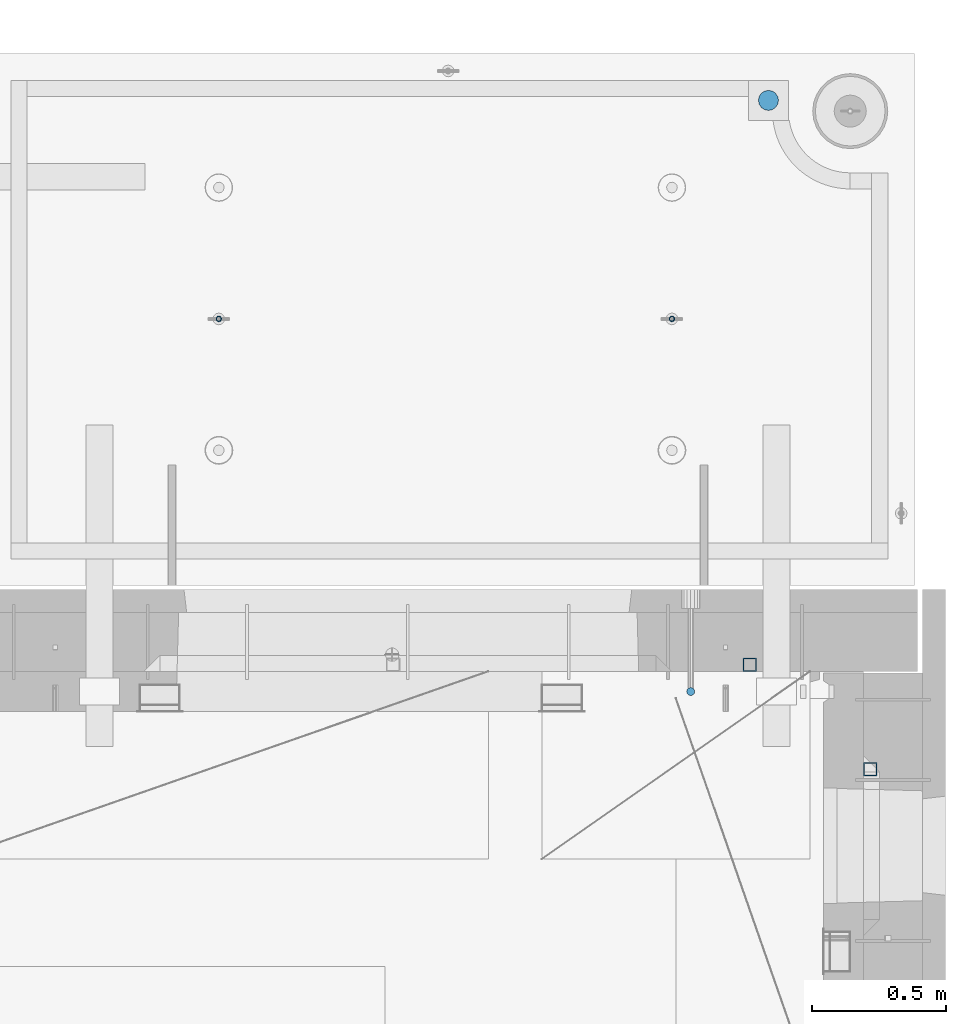
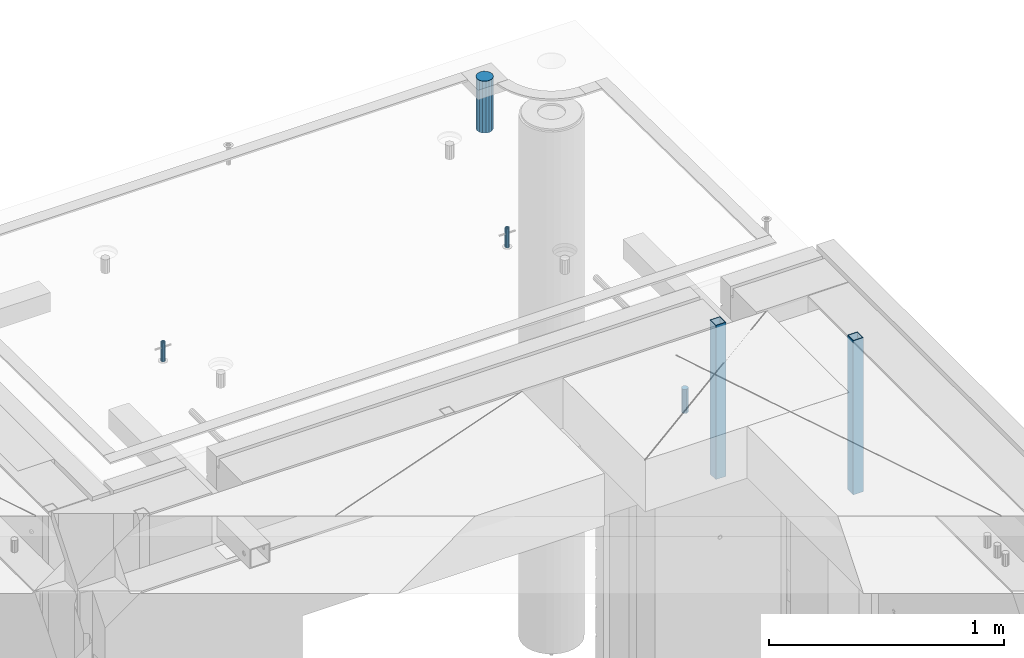
# One storey, part 37 of 350: 6 columns, 7 elements without a shape of their own.
"""IFC2X3 building model written with IfcOpenShell, lengths in millimetres."""

from ifc_helpers import new_model, si_unit, frame, origin_with_axes, place, context, subcontext, project, spatial, faceted_brep, material, type_object, element, aggregate, save


model = new_model("IFC2X3")

# Units and contexts
model_context = context("Model", 3, precision=1e-05, world=origin_with_axes())
body_context = subcontext(model_context, "Body", "Model", "MODEL_VIEW")
ifc_project = project(units=[si_unit("LENGTHUNIT", "METRE", prefix="MILLI"), si_unit("AREAUNIT", "SQUARE_METRE"), si_unit("VOLUMEUNIT", "CUBIC_METRE"), si_unit("MASSUNIT", "GRAM", prefix="KILO"), si_unit("TIMEUNIT", "SECOND"), si_unit("PLANEANGLEUNIT", "RADIAN"), si_unit("SOLIDANGLEUNIT", "STERADIAN"), si_unit("THERMODYNAMICTEMPERATUREUNIT", "DEGREE_CELSIUS"), si_unit("LUMINOUSINTENSITYUNIT", "LUMEN")], contexts=[model_context])

# Site, building, storey
site_placement = place(None, origin_with_axes())
site = spatial("IfcSite", under=ifc_project, at=site_placement, CompositionType="ELEMENT")
building_placement = place(site_placement, origin_with_axes())
building = spatial("IfcBuilding", under=site, at=building_placement, CompositionType="ELEMENT")
storey_placement = place(building_placement, origin_with_axes())
storey = spatial("IfcBuildingStorey", under=building, at=storey_placement, Name="2", CompositionType="ELEMENT", Elevation=0.0)

# Assembly, column
assembly_1_placement = place(storey_placement, origin_with_axes())
assembly_1 = element("IfcElementAssembly", 1, at=assembly_1_placement, inside=storey, AssemblyPlace="NOTDEFINED", PredefinedType="REINFORCEMENT_UNIT")
ifc_material_1 = material()
column_type_1 = type_object("IfcColumnType", Name="D30", PredefinedType="NOTDEFINED")
column_1_placement = place(assembly_1_placement, frame((34415.0073334623, 20504.9951872205, 87407.5), z_axis=(0.0, -1.0, 0.0), x_axis=(0.0, 0.0, 1.0)))
column_1 = element("IfcColumn", 2, at=column_1_placement, type_object=column_type_1, material=ifc_material_1, ObjectType="D30", context=body_context, shape_type="Brep", body=[
    faceted_brep([(0.0, -15.0, 0.0), (0.0, -12.9903810567666, -7.5), (125.0, -12.9903810567666, -7.5), (125.0, -15.0, 0.0), (0.0, -7.5, -12.9903810567666), (125.0, -7.5, -12.9903810567666), (0.0, 0.0, -15.0), (125.0, 0.0, -15.0), (0.0, 7.5, -12.9903810567666), (125.0, 7.5, -12.9903810567666), (0.0, 12.9903810567666, -7.5), (125.0, 12.9903810567666, -7.5), (0.0, 15.0, 0.0), (125.0, 15.0, 0.0), (0.0, 12.9903810567666, 7.5), (125.0, 12.9903810567666, 7.5), (0.0, 7.5, 12.9903810567666), (125.0, 7.5, 12.9903810567666), (0.0, 0.0, 15.0), (125.0, 0.0, 15.0), (0.0, -7.5, 12.9903810567666), (125.0, -7.5, 12.9903810567666), (0.0, -12.9903810567666, 7.5), (125.0, -12.9903810567666, 7.5)], [[[0, 1, 2, 3]], [[1, 4, 5, 2]], [[4, 6, 7, 5]], [[6, 8, 9, 7]], [[8, 10, 11, 9]], [[10, 12, 13, 11]], [[12, 14, 15, 13]], [[14, 16, 17, 15]], [[16, 18, 19, 17]], [[18, 20, 21, 19]], [[20, 22, 23, 21]], [[22, 0, 3, 23]], [[5, 7, 9, 11, 13, 15, 17, 19, 21, 23, 3, 2]], [[22, 20, 18, 16, 14, 12, 10, 8, 6, 4, 1, 0]]]),
])

# Assemblies, column
assembly_2_placement = place(storey_placement, origin_with_axes())
assembly_2 = element("IfcElementAssembly", 3, at=assembly_2_placement, inside=storey, AssemblyPlace="NOTDEFINED", PredefinedType="REINFORCEMENT_UNIT")
assembly_3_placement = place(assembly_2_placement, origin_with_axes())
assembly_3 = element("IfcElementAssembly", 4, at=assembly_3_placement, Name="Steel Assembly", AssemblyPlace="NOTDEFINED", PredefinedType="RIGID_FRAME")
aggregate(assembly_2, [assembly_3])
ifc_material_2 = material(Name="STEEL/S355J2")
column_type_2 = type_object("IfcColumnType", Name="50X50X3", PredefinedType="NOTDEFINED")
column_2_placement = place(assembly_3_placement, frame((35085.0, 20215.0002861023, 86940.0), z_axis=(0.0, -1.0, 0.0), x_axis=(0.0, 0.0, 1.0)))
column_2 = element("IfcColumn", 5, at=column_2_placement, type_object=column_type_2, material=ifc_material_2, ObjectType="50X50X3", context=body_context, shape_type="Brep", body=[
    faceted_brep([(0.0, 22.0, -22.0), (0.0, -22.0, -22.0), (800.0, -22.0, -22.0), (800.0, 22.0, -22.0), (0.0, -22.0, 22.0), (800.0, -22.0, 22.0), (0.0, 22.0, 22.0), (800.0, 22.0, 22.0), (0.0, 25.0, -25.0), (0.0, 25.0, 25.0), (800.0, 25.0, 25.0), (800.0, 25.0, -25.0), (0.0, -25.0, 25.0), (800.0, -25.0, 25.0), (0.0, -25.0, -25.0), (800.0, -25.0, -25.0)], [[[0, 1, 2, 3]], [[1, 4, 5, 2]], [[4, 6, 7, 5]], [[6, 0, 3, 7]], [[8, 9, 10, 11]], [[9, 12, 13, 10]], [[12, 14, 15, 13]], [[14, 8, 11, 15]], [[13, 15, 11, 10], [5, 7, 3, 2]], [[14, 12, 9, 8], [6, 4, 1, 0]]]),
])
aggregate(assembly_3, [column_2])

# Assembly
assembly_4_placement = place(assembly_1_placement, origin_with_axes())
assembly_4 = element("IfcElementAssembly", 6, at=assembly_4_placement, Name="Steel Assembly", AssemblyPlace="NOTDEFINED", PredefinedType="RIGID_FRAME")

aggregate(assembly_1, [column_1, assembly_4])

# Column
column_3_placement = place(assembly_4_placement, frame((34635.0, 20605.0, 86940.0), z_axis=(1.0, 0.0, 0.0), x_axis=(0.0, 0.0, 1.0)))
column_3 = element("IfcColumn", 7, at=column_3_placement, type_object=column_type_2, material=ifc_material_2, ObjectType="50X50X3", context=body_context, shape_type="Brep", body=[
    faceted_brep([(0.0, 22.0, -22.0), (0.0, -22.0, -22.0), (800.0, -22.0, -22.0), (800.0, 22.0, -22.0), (0.0, -22.0, 22.0), (800.0, -22.0, 22.0), (0.0, 22.0, 22.0), (800.0, 22.0, 22.0), (0.0, 25.0, -25.0), (0.0, 25.0, 25.0), (800.0, 25.0, 25.0), (800.0, 25.0, -25.0), (0.0, -25.0, 25.0), (800.0, -25.0, 25.0), (0.0, -25.0, -25.0), (800.0, -25.0, -25.0)], [[[0, 1, 2, 3]], [[1, 4, 5, 2]], [[4, 6, 7, 5]], [[6, 0, 3, 7]], [[8, 9, 10, 11]], [[9, 12, 13, 10]], [[12, 14, 15, 13]], [[14, 8, 11, 15]], [[13, 15, 11, 10], [5, 7, 3, 2]], [[14, 12, 9, 8], [6, 4, 1, 0]]]),
])

aggregate(assembly_4, [column_3])

# Assemblies, columns
assembly_5_placement = place(storey_placement, origin_with_axes())
assembly_5 = element("IfcElementAssembly", 8, at=assembly_5_placement, inside=storey, AssemblyPlace="NOTDEFINED", PredefinedType="REINFORCEMENT_UNIT")
assembly_6_placement = place(assembly_5_placement, origin_with_axes())
assembly_6 = element("IfcElementAssembly", 9, at=assembly_6_placement, Name="Steel Assembly", AssemblyPlace="NOTDEFINED", PredefinedType="RIGID_FRAME")
ifc_material_3 = material(Name="STEEL/1.4301")
column_type_3 = type_object("IfcColumnType", PredefinedType="NOTDEFINED")
column_4_placement = place(assembly_6_placement, frame((32654.9901431868, 21895.0034426477, 87445.0), z_axis=(0.000321686000089053, -0.999999948259057, 0.0), x_axis=(0.0, 0.0, 1.0)))
column_4 = element("IfcColumn", 10, at=column_4_placement, type_object=column_type_3, material=ifc_material_3, context=body_context, shape_type="Brep", body=[
    faceted_brep([(0.0, -8.0, 0.0), (0.0, -6.92820323027263, 4.0), (100.000000000029, -6.92820323027263, 4.0), (100.000000000029, -7.99999999999636, 0.0), (0.0, -4.0, 6.92820323027627), (100.000000000029, -4.0, 6.92820323027536), (0.0, 0.0, 8.0), (100.000000000029, 3.63797880709171e-12, 8.0), (0.0, 4.0, 6.92820323027627), (100.000000000029, 4.0, 6.92820323027536), (0.0, 6.92820323027263, 4.0), (100.000000000029, 6.92820323027627, 3.99999999999909), (0.0, 8.0, 0.0), (100.000000000029, 8.0, 0.0), (0.0, 6.92820323027263, -4.0), (100.000000000029, 6.92820323027627, -4.00000000000091), (0.0, 4.0, -6.92820323027627), (100.000000000029, 4.00000000000364, -6.92820323027536), (0.0, 0.0, -8.0), (100.000000000029, 3.63797880709171e-12, -8.00000000000091), (0.0, -4.0, -6.92820323027627), (100.000000000029, -3.99999999999636, -6.92820323027627), (0.0, -6.92820323027263, -4.0), (100.000000000029, -6.92820323027263, -4.0), (0.0, -10.4999999999927, -1.45519152283669e-11), (0.0, -9.09326673972828, -5.25000000001455), (100.000000000262, -9.09326673972828, -5.25000000001455), (100.000000000262, -10.4999999999927, -1.45519152283669e-11), (0.0, -5.24999999998545, -9.09326673974283), (100.000000000262, -5.24999999998545, -9.09326673974283), (0.0, 7.27595761418343e-12, -10.5), (100.000000000262, 7.27595761418343e-12, -10.5), (0.0, 5.25000000001455, -9.09326673975738), (100.000000000262, 5.25000000001455, -9.09326673975738), (0.0, 9.09326673975011, -5.25000000001455), (100.000000000262, 9.09326673975011, -5.25000000001455), (0.0, 10.5000000000073, -1.45519152283669e-11), (100.000000000262, 10.5000000000073, -1.45519152283669e-11), (0.0, 9.09326673975011, 5.25), (100.000000000262, 9.09326673975011, 5.25), (0.0, 5.25000000000728, 9.09326673972828), (100.000000000262, 5.25000000000728, 9.09326673972828), (0.0, 1.45519152283669e-11, 10.4999999999854), (100.000000000262, 1.45519152283669e-11, 10.4999999999854), (0.0, -5.24999999999272, 9.09326673972828), (100.000000000262, -5.24999999999272, 9.09326673972828), (0.0, -9.09326673972828, 5.24999999998545), (100.000000000262, -9.09326673972828, 5.24999999998545)], [[[0, 1, 2, 3]], [[1, 4, 5, 2]], [[4, 6, 7, 5]], [[6, 8, 9, 7]], [[8, 10, 11, 9]], [[10, 12, 13, 11]], [[12, 14, 15, 13]], [[14, 16, 17, 15]], [[16, 18, 19, 17]], [[18, 20, 21, 19]], [[20, 22, 23, 21]], [[22, 0, 3, 23]], [[24, 25, 26, 27]], [[25, 28, 29, 26]], [[28, 30, 31, 29]], [[30, 32, 33, 31]], [[32, 34, 35, 33]], [[34, 36, 37, 35]], [[36, 38, 39, 37]], [[38, 40, 41, 39]], [[40, 42, 43, 41]], [[42, 44, 45, 43]], [[44, 46, 47, 45]], [[46, 24, 27, 47]], [[29, 31, 33, 35, 37, 39, 41, 43, 45, 47, 27, 26], [5, 7, 9, 11, 13, 15, 17, 19, 21, 23, 3, 2]], [[46, 44, 42, 40, 38, 36, 34, 32, 30, 28, 25, 24], [22, 20, 18, 16, 14, 12, 10, 8, 6, 4, 1, 0]]]),
])
aggregate(assembly_6, [column_4])
assembly_7_placement = place(assembly_5_placement, origin_with_axes())
assembly_7 = element("IfcElementAssembly", 11, at=assembly_7_placement, Name="Steel Assembly", AssemblyPlace="NOTDEFINED", PredefinedType="RIGID_FRAME")
column_5_placement = place(assembly_7_placement, frame((34345.0001431868, 21895.0034426477, 87445.0), z_axis=(0.000321686000089053, -0.999999948259057, 0.0), x_axis=(0.0, 0.0, 1.0)))
column_5 = element("IfcColumn", 12, at=column_5_placement, type_object=column_type_3, material=ifc_material_3, context=body_context, shape_type="Brep", body=[
    faceted_brep([(0.0, -8.0, 0.0), (0.0, -6.92820323027263, 4.0), (100.000000000029, -6.92820323027263, 4.0), (100.000000000029, -7.99999999999636, 0.0), (0.0, -4.0, 6.92820323027627), (100.000000000029, -4.0, 6.92820323027536), (0.0, 0.0, 8.0), (100.000000000029, 3.63797880709171e-12, 8.0), (0.0, 4.0, 6.92820323027627), (100.000000000029, 4.0, 6.92820323027536), (0.0, 6.92820323027263, 4.0), (100.000000000029, 6.92820323027627, 3.99999999999909), (0.0, 8.0, 0.0), (100.000000000029, 8.0, 0.0), (0.0, 6.92820323027263, -4.0), (100.000000000029, 6.92820323027627, -4.00000000000091), (0.0, 4.0, -6.92820323027627), (100.000000000029, 4.00000000000364, -6.92820323027536), (0.0, 0.0, -8.0), (100.000000000029, 3.63797880709171e-12, -8.00000000000091), (0.0, -4.0, -6.92820323027627), (100.000000000029, -3.99999999999636, -6.92820323027627), (0.0, -6.92820323027263, -4.0), (100.000000000029, -6.92820323027263, -4.0), (0.0, -10.4999999999927, -1.45519152283669e-11), (0.0, -9.09326673972828, -5.25000000001455), (100.000000000262, -9.09326673972828, -5.25000000001455), (100.000000000262, -10.4999999999927, -1.45519152283669e-11), (0.0, -5.24999999998545, -9.09326673974283), (100.000000000262, -5.24999999998545, -9.09326673974283), (0.0, 7.27595761418343e-12, -10.5), (100.000000000262, 7.27595761418343e-12, -10.5), (0.0, 5.25000000001455, -9.09326673975738), (100.000000000262, 5.25000000001455, -9.09326673975738), (0.0, 9.09326673975011, -5.25000000001455), (100.000000000262, 9.09326673975011, -5.25000000001455), (0.0, 10.5000000000073, -1.45519152283669e-11), (100.000000000262, 10.5000000000073, -1.45519152283669e-11), (0.0, 9.09326673975011, 5.25), (100.000000000262, 9.09326673975011, 5.25), (0.0, 5.25000000000728, 9.09326673972828), (100.000000000262, 5.25000000000728, 9.09326673972828), (0.0, 1.45519152283669e-11, 10.4999999999854), (100.000000000262, 1.45519152283669e-11, 10.4999999999854), (0.0, -5.24999999999272, 9.09326673972828), (100.000000000262, -5.24999999999272, 9.09326673972828), (0.0, -9.09326673972828, 5.24999999998545), (100.000000000262, -9.09326673972828, 5.24999999998545)], [[[0, 1, 2, 3]], [[1, 4, 5, 2]], [[4, 6, 7, 5]], [[6, 8, 9, 7]], [[8, 10, 11, 9]], [[10, 12, 13, 11]], [[12, 14, 15, 13]], [[14, 16, 17, 15]], [[16, 18, 19, 17]], [[18, 20, 21, 19]], [[20, 22, 23, 21]], [[22, 0, 3, 23]], [[24, 25, 26, 27]], [[25, 28, 29, 26]], [[28, 30, 31, 29]], [[30, 32, 33, 31]], [[32, 34, 35, 33]], [[34, 36, 37, 35]], [[36, 38, 39, 37]], [[38, 40, 41, 39]], [[40, 42, 43, 41]], [[42, 44, 45, 43]], [[44, 46, 47, 45]], [[46, 24, 27, 47]], [[29, 31, 33, 35, 37, 39, 41, 43, 45, 47, 27, 26], [5, 7, 9, 11, 13, 15, 17, 19, 21, 23, 3, 2]], [[46, 44, 42, 40, 38, 36, 34, 32, 30, 28, 25, 24], [22, 20, 18, 16, 14, 12, 10, 8, 6, 4, 1, 0]]]),
])
aggregate(assembly_7, [column_5])
ifc_material_4 = material()
column_type_4 = type_object("IfcColumnType", Name="D75", PredefinedType="NOTDEFINED")
column_6_placement = place(assembly_5_placement, frame((34704.9998568133, 22710.1651093338, 87440.0), z_axis=(0.9999999949993, 0.000100007000000845, 0.0), x_axis=(0.0, 0.0, 1.0)))
column_6 = element("IfcColumn", 13, at=column_6_placement, type_object=column_type_4, material=ifc_material_4, ObjectType="D75", context=body_context, shape_type="Brep", body=[
    faceted_brep([(0.0, -37.4999999999991, 1.81898940354586e-12), (0.0, -34.6454824691718, -14.3506287136888), (270.0, -34.6454824691718, -14.3506287136888), (270.0, -37.4999999999991, 1.81898940354586e-12), (0.0, -26.5165042944936, -26.5165042944936), (270.0, -26.5165042944936, -26.5165042944936), (0.0, -14.3506287136906, -34.6454824691718), (270.0, -14.3506287136906, -34.6454824691718), (0.0, 9.09494701772928e-13, -37.4999999999982), (270.0, 9.09494701772928e-13, -37.4999999999982), (0.0, 14.3506287136915, -34.6454824691718), (270.0, 14.3506287136915, -34.6454824691718), (0.0, 26.5165042944973, -26.5165042944927), (270.0, 26.5165042944973, -26.5165042944927), (0.0, 34.6454824691746, -14.3506287136897), (270.0, 34.6454824691746, -14.3506287136897), (0.0, 37.5000000000018, 1.81898940354586e-12), (270.0, 37.5000000000018, 1.81898940354586e-12), (0.0, 34.6454824691755, 14.3506287136925), (270.0, 34.6454824691755, 14.3506287136925), (0.0, 26.5165042944964, 26.5165042944973), (270.0, 26.5165042944964, 26.5165042944973), (0.0, 14.3506287136934, 34.6454824691755), (270.0, 14.3506287136934, 34.6454824691755), (0.0, 1.81898940354586e-12, 37.5000000000027), (270.0, 1.81898940354586e-12, 37.5000000000027), (0.0, -14.3506287136897, 34.6454824691746), (270.0, -14.3506287136897, 34.6454824691746), (0.0, -26.5165042944946, 26.5165042944973), (270.0, -26.5165042944946, 26.5165042944973), (0.0, -34.6454824691718, 14.3506287136925), (270.0, -34.6454824691718, 14.3506287136925)], [[[0, 1, 2, 3]], [[1, 4, 5, 2]], [[4, 6, 7, 5]], [[6, 8, 9, 7]], [[8, 10, 11, 9]], [[10, 12, 13, 11]], [[12, 14, 15, 13]], [[14, 16, 17, 15]], [[16, 18, 19, 17]], [[18, 20, 21, 19]], [[20, 22, 23, 21]], [[22, 24, 25, 23]], [[24, 26, 27, 25]], [[26, 28, 29, 27]], [[28, 30, 31, 29]], [[30, 0, 3, 31]], [[5, 7, 9, 11, 13, 15, 17, 19, 21, 23, 25, 27, 29, 31, 3, 2]], [[30, 28, 26, 24, 22, 20, 18, 16, 14, 12, 10, 8, 6, 4, 1, 0]]]),
])
aggregate(assembly_5, [assembly_6, assembly_7, column_6])

save(model, "model.ifc")
